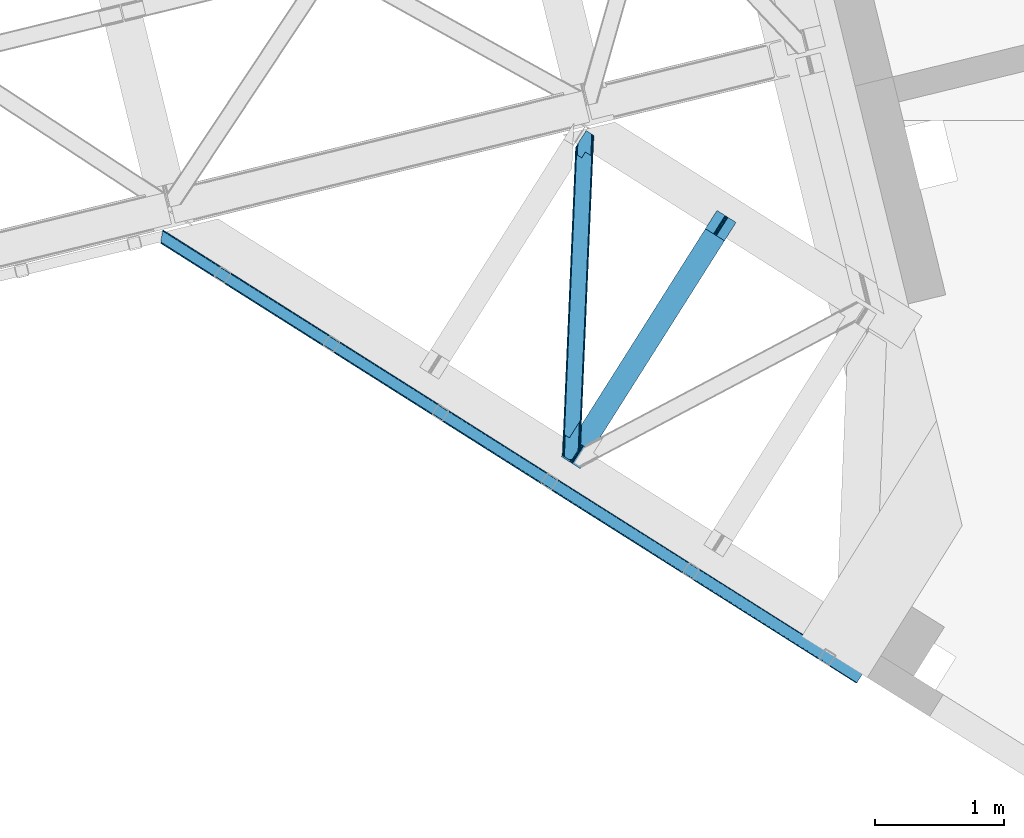
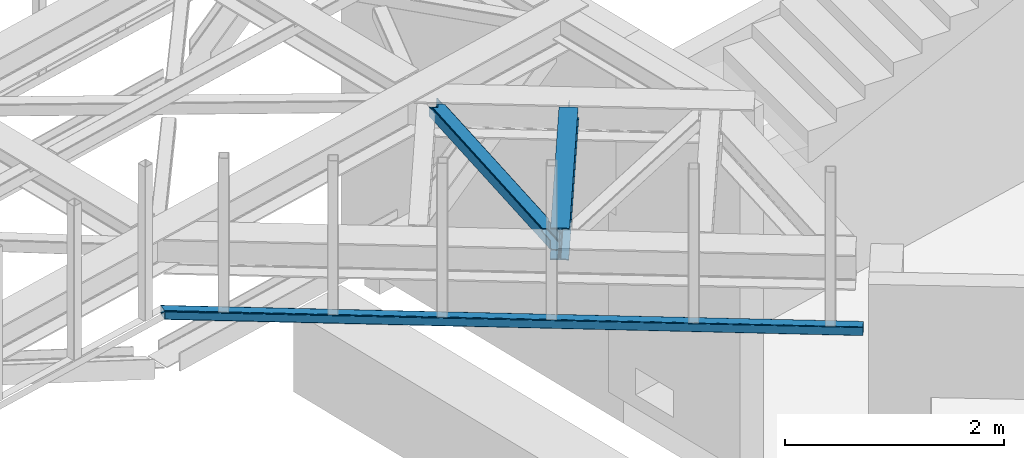
# One storey, part 49 of 66: 2 beams, 1 member.
"""IFC4 building model written with IfcOpenShell, lengths in millimetres."""

from ifc_helpers import new_model, entity, si_unit, converted_unit, derived_unit, direction, frame, origin, place, context, subcontext, project, spatial, triangles, polygons, material, type_object, element, save


model = new_model("IFC4")

# Units and contexts
model_context = context("Model", 3, precision=0.01, world=origin(), true_north=direction((6.12303176911189e-17, 1.0)))
plan_context = context("Plan", 3, precision=0.01, world=origin(), true_north=direction((6.12303176911189e-17, 1.0)))
body_context = subcontext(model_context, "Body", "Model", "MODEL_VIEW")
ifc_project = project(units=[si_unit("LENGTHUNIT", "METRE", prefix="MILLI"), si_unit("AREAUNIT", "SQUARE_METRE"), si_unit("VOLUMEUNIT", "CUBIC_METRE"), converted_unit("PLANEANGLEUNIT", "DEGREE", entity("IfcRatioMeasure", 0.0174532925199433), si_unit("PLANEANGLEUNIT", "RADIAN"), dimensions=[0, 0, 0, 0, 0, 0, 0]), si_unit("MASSUNIT", "GRAM", prefix="KILO"), derived_unit("MASSDENSITYUNIT", [(si_unit("MASSUNIT", "GRAM", prefix="KILO"), 1), (si_unit("LENGTHUNIT", "METRE"), -3)]), derived_unit("MOMENTOFINERTIAUNIT", [(si_unit("LENGTHUNIT", "METRE"), 4)]), si_unit("TIMEUNIT", "SECOND"), si_unit("FREQUENCYUNIT", "HERTZ"), si_unit("THERMODYNAMICTEMPERATUREUNIT", "DEGREE_CELSIUS"), derived_unit("THERMALTRANSMITTANCEUNIT", [(si_unit("MASSUNIT", "GRAM", prefix="KILO"), 1), (si_unit("THERMODYNAMICTEMPERATUREUNIT", "KELVIN"), -1), (si_unit("TIMEUNIT", "SECOND"), -3)]), derived_unit("VOLUMETRICFLOWRATEUNIT", [(si_unit("LENGTHUNIT", "METRE"), 3), (si_unit("TIMEUNIT", "SECOND"), -1)]), derived_unit("MASSFLOWRATEUNIT", [(si_unit("MASSUNIT", "GRAM", prefix="KILO"), 1), (si_unit("TIMEUNIT", "SECOND"), -1)]), derived_unit("ROTATIONALFREQUENCYUNIT", [(si_unit("TIMEUNIT", "SECOND"), -1)]), si_unit("ELECTRICCURRENTUNIT", "AMPERE"), si_unit("ELECTRICVOLTAGEUNIT", "VOLT"), si_unit("POWERUNIT", "WATT"), si_unit("FORCEUNIT", "NEWTON", prefix="KILO"), si_unit("ILLUMINANCEUNIT", "LUX"), si_unit("LUMINOUSFLUXUNIT", "LUMEN"), si_unit("LUMINOUSINTENSITYUNIT", "CANDELA"), derived_unit("USERDEFINED", [(si_unit("MASSUNIT", "GRAM", prefix="KILO"), -1), (si_unit("LENGTHUNIT", "METRE"), -2), (si_unit("TIMEUNIT", "SECOND"), 3), (si_unit("LUMINOUSFLUXUNIT", "LUMEN"), 1)]), derived_unit("LINEARVELOCITYUNIT", [(si_unit("LENGTHUNIT", "METRE"), 1), (si_unit("TIMEUNIT", "SECOND"), -1)]), si_unit("PRESSUREUNIT", "PASCAL"), derived_unit("USERDEFINED", [(si_unit("LENGTHUNIT", "METRE"), -2), (si_unit("MASSUNIT", "GRAM", prefix="KILO"), 1), (si_unit("TIMEUNIT", "SECOND"), -2)]), derived_unit("LINEARFORCEUNIT", [(si_unit("MASSUNIT", "GRAM", prefix="KILO"), 1), (si_unit("LENGTHUNIT", "METRE"), 1), (si_unit("TIMEUNIT", "SECOND"), -2), (si_unit("LENGTHUNIT", "METRE"), -1)]), derived_unit("PLANARFORCEUNIT", [(si_unit("MASSUNIT", "GRAM", prefix="KILO"), 1), (si_unit("LENGTHUNIT", "METRE"), 1), (si_unit("TIMEUNIT", "SECOND"), -2), (si_unit("LENGTHUNIT", "METRE"), -2)])], contexts=[model_context, plan_context])

# Site, building, storey
site_placement = place(None, origin())
site = spatial("IfcSite", under=ifc_project, at=site_placement, CompositionType="ELEMENT")
building_placement = place(site_placement, origin())
building = spatial("IfcBuilding", under=site, at=building_placement, CompositionType="ELEMENT")
storey_placement = place(building_placement, frame((0.0, 0.0, 19800.0)))
storey = spatial("IfcBuildingStorey", under=building, at=storey_placement, Name="06", CompositionType="ELEMENT", Elevation=19800.0)

# Beam
ifc_material = material(Name="Metal painted (White)")
beam_type_1 = type_object("IfcBeamType", PredefinedType="BEAM")
beam_1_placement = place(storey_placement, frame((-2373.15, 14260.29, 3864.0)))
element("IfcBeam", 1, at=beam_1_placement, inside=storey, type_object=beam_type_1, material=ifc_material, ObjectType="Steel Beam", PredefinedType="BEAM", context=body_context, shape_type="Tessellation", body=[
    polygons([(147.919660694801, 2.16573425859679e-12, 11.0000000000018), (147.919660694804, 4.33146851719357e-12, 0.0), (1355.44607863557, 1910.06544717356, 0.0), (1355.44607863557, 1910.06544717355, 11.0000000000018), (90.4423068248274, 36.3366728266057, 11.0000000000018), (1297.96872476558, 1946.40212000016, 11.0000000000018), (85.2668642219479, 39.6085416920184, 12.2179274798152), (1292.7932821627, 1949.67398886557, 12.2179274798152), (80.8793358398553, 42.3822981822298, 15.6862915010257), (1288.40575378062, 1952.44774535578, 15.6862915010213), (77.9476831016699, 44.2356630157985, 20.8770650821548), (1285.47410104242, 1954.30111018934, 20.8770650821548), (76.9182235613008, 44.8864781975669, 26.9999999999939), (1284.44464150205, 1954.95192537111, 26.9999999999939), (1278.52785507426, 1958.69246522089, 26.9999999999939), (1278.52785507432, 1958.69246522022, 203.000000000006), (1284.44464150196, 1954.95192537085, 203.000000000006), (1207.52641794078, 2003.57894341848, 0.0), (1207.52641794077, 2003.57894341847, 10.9999999999975), (1265.00377181074, 1967.24227059188, 11.0000000000018), (1270.17921441362, 1963.97040172646, 12.2179274798152), (1274.56674279571, 1961.19664523624, 15.6862915010127), (1277.49839553388, 1959.34328040268, 20.8770650821592), (76.9182235613823, 44.8864781975192, 203.000000000006), (71.0014371335516, 48.6270180473361, 203.000000000006), (71.0014371335056, 48.6270180473665, 26.9999999999939), (69.9719775931373, 49.2778332291413, 20.8770650821592), (67.0403248549565, 51.1311980626949, 15.6862915010127), (62.6527964728685, 53.9049545529128, 12.2179274798152), (57.4773538699869, 57.176823418332, 11.0000000000018), (8.12150346973795e-12, 93.5134962449225, 10.9999999999975), (5.41433564649196e-12, 93.5134962449269, 0.0), (162.887980343835, 180.873386503032, 203.069792575793), (1195.07248712349, 1813.58297531797, 203.006342981529), (1194.53809439775, 1812.73773730252, 216.999999999998), (163.217821525431, 181.395193639939, 216.999999999998), (163.217821525544, 181.395193639874, 204.00000000001), (156.766642341062, 184.290495421957, 203.006342980143), (157.301035097542, 185.135733489758, 216.999999999998), (1188.62130797009, 1816.4782771522, 216.999999999998), (1188.6213079702, 1816.47827715213, 204.000000000006), (1188.95114918025, 1817.00008434255, 203.069791966819), (157.301035097816, 185.135733489578, 204.00000000001), (164.247281065643, 180.744378458268, 223.122934917842), (167.178933803824, 178.891013624725, 228.313708498975), (171.566462185928, 176.117257134518, 231.782072520173), (176.741904788822, 172.845388269138, 232.999999999995), (234.219258658959, 136.508715442803, 232.999999999999), (234.219258658962, 136.508715442803, 243.999999999997), (86.2995979637529, 230.022211687052, 244.000000000001), (86.2995979637521, 230.022211687052, 232.999999999999), (143.776951833897, 193.685538860712, 232.999999999999), (148.952394436778, 190.413669995315, 231.782072520181), (153.339922818875, 187.639913505108, 228.313708498984), (156.271575557062, 185.786548671563, 223.122934917842), (1187.59184842946, 1817.12909233409, 223.122934917842), (1184.66019569129, 1818.98245716763, 228.313708498979), (1180.27266730917, 1821.75621365784, 231.782072520181), (1175.0972247063, 1825.02808252324, 232.999999999999), (1117.61987083616, 1861.36475534957, 232.999999999999), (1117.61987083616, 1861.36475534957, 244.000000000001), (1265.53953153138, 1767.85125910532, 243.999999999997), (1265.53953153137, 1767.85125910532, 232.999999999999), (1208.06217766123, 1804.18793193166, 232.999999999995), (1202.88673505832, 1807.45980079704, 231.782072520173), (1198.49920667623, 1810.23355728725, 228.313708498975), (1195.56755393804, 1812.08692212079, 223.122934917842), (1194.53809439802, 1812.73773730233, 204.000000000006)], [[[1, 2, 3, 4]], [[5, 1, 4, 6]], [[7, 5, 6, 8]], [[9, 7, 8, 10]], [[11, 9, 10, 12]], [[13, 11, 12, 14]], [[15, 16, 17, 14, 12, 10, 8, 6, 4, 3, 18, 19, 20, 21, 22, 23]], [[13, 24, 25, 26, 27, 28, 29, 30, 31, 32, 2, 1, 5, 7, 9, 11]], [[2, 32, 18, 3]], [[32, 31, 19, 18]], [[31, 30, 20, 19]], [[27, 26, 15, 23]], [[28, 27, 23, 22]], [[29, 28, 22, 21]], [[30, 29, 21, 20]], [[33, 24, 13, 14, 17, 34, 35, 36, 37]], [[25, 38, 39, 40, 41, 42, 16, 15, 26]], [[38, 25, 24, 33]], [[42, 34, 17, 16]], [[39, 43, 37, 36, 44, 45, 46, 47, 48, 49, 50, 51, 52, 53, 54, 55]], [[40, 56, 57, 58, 59, 60, 61, 62, 63, 64, 65, 66, 67, 35, 68, 41]], [[44, 36, 35, 67]], [[45, 44, 67, 66]], [[46, 45, 66, 65]], [[47, 46, 65, 64]], [[48, 47, 64, 63]], [[49, 48, 63, 62]], [[50, 49, 62, 61]], [[51, 50, 61, 60]], [[52, 51, 60, 59]], [[53, 52, 59, 58]], [[54, 53, 58, 57]], [[55, 54, 57, 56]], [[39, 55, 56, 40]]], closed=False),
])

# Member
member_type = type_object("IfcMemberType", PredefinedType="BRACE")
member_placement = place(storey_placement, frame((-2366.79, 14329.55, 3964.0)))
element("IfcMember", 2, at=member_placement, inside=storey, type_object=member_type, ObjectType="Steel Horizontal Brace", PredefinedType="BRACE", context=body_context, shape_type="Tessellation", body=[
    triangles([(100.655629348755, 2374.38995361328, 113.0000793457), (107.475271224976, 2370.07742614746, 113.0000793457), (102.696783828736, 2421.82891845703, 113.0000793457), (109.879194259644, 2433.19217834473, 113.0000793457), (110.120894622803, 2433.18287658691, 113.0000793457), (107.407542800903, 2370.08091430664, 113.0000793457), (110.142259597778, 2433.72354125977, 112.135015869138), (107.407397460938, 2370.08091430664, 115.49992675781), (13.930835723877, 195.896182250977, 115.49992675781), (110.180774688721, 2433.72237854004, 24.4985046386719), (13.8035179138183, 192.844042968751, 111.22111816406), (6.85336074829092, 30.4120971679695, 24.4985046386719), (13.6123958587646, 188.365246582032, 109.609588623047), (13.4169136047362, 183.884124755859, 108.000384521481), (6.81949653625497, 30.4144226074222, 108.000384521481), (0.0, 34.7257873535164, 108.000384521481), (6.82414741516141, 30.4144226074222, 108.000384521481), (13.4262153625491, 183.885287475587, 108.000384521481), (6.6020679473877, 188.196652221681, 108.000384521481), (6.98896293640155, 197.155407714845, 111.22111816406), (13.808604812622, 192.842880249023, 111.22111816406), (13.9405735015871, 195.89501953125, 115.49992675781), (14.3164226531985, 196.336853027344, 118.999713134763), (7.14723815917978, 200.865646362305, 118.999713134763), (7.06817321777362, 199.011108398438, 115.109252929688), (13.6174827575683, 188.364083862305, 109.609588623047), (6.79784088134784, 192.676611328125, 109.609588623047), (15.8281036376952, 195.378771972657, 121.887908935547), (108.771703720093, 2369.25654602051, 122.19719238281), (112.471768569947, 2366.92064208984, 127.873590087889), (107.475271224976, 2370.07742614746, 115.49992675781), (18.9633773803712, 193.396334838868, 127.873590087889), (118.001518249512, 2363.42318115235, 131.666381835938), (24.4974872589114, 189.900036621095, 131.666381835938), (124.526556015015, 2359.29668884277, 132.998858642575), (31.0226703643798, 185.773544311523, 132.998858642575), (129.009131240845, 2463.45079650879, 6.99957275390625), (121.8158203125, 2452.07358398438, 8.33204956054396), (23.8754322052005, 19.6336853027351, 6.99957275390625), (17.3502490997316, 23.7590148925792, 8.33204956054396), (115.717791366577, 2442.42882385254, 12.1248413085923), (11.8161392211914, 27.2564758300778, 12.1248413085923), (111.644784164429, 2435.9838684082, 17.8035644531228), (8.12043457031268, 29.5935424804684, 17.8035644531228), (110.214638900757, 2433.72121582031, 24.4985046386719), (6.82414741516141, 30.4144226074222, 24.4985046386719), (102.696783828736, 2421.82891845703, 17.4989318847656), (100.655629348755, 2374.38995361328, 122.499499511716), (7.14723815917978, 200.865646362305, 122.499499511716), (0.0, 34.7257873535164, 17.4989318847656), (117.706914138794, 2363.6092163086, 139.998431396481), (111.181876373291, 2367.73570861817, 138.668280029295), (17.6778453826905, 194.212564086914, 138.668280029295), (24.2030284881594, 190.086071777345, 139.998431396481), (105.647621154785, 2371.23200683594, 134.873162841795), (12.1437355041503, 197.708862304688, 134.873162841795), (101.952061843872, 2373.56907348633, 129.196765136716), (8.44817619323749, 200.045928955078, 129.196765136716), (151.68507270813, 2342.12680664063, 132.998858642575), (151.68507270813, 2342.12680664063, 139.998431396481), (56.1432300567626, 169.89428100586, 132.998858642575), (56.1432300567626, 169.89428100586, 139.998431396481), (104.126929092407, 2424.09273376465, 10.8016662597656), (1.30093803405771, 33.9060699462898, 10.8016662597656), (108.200081634522, 2430.53652648926, 5.12526855468604), (4.99649734497098, 31.5690032958992, 5.12526855468604), (114.298110580444, 2440.18244934082, 1.33247680663771), (10.5307525634767, 28.0715423583988, 1.33247680663771), (121.491276168823, 2451.55966186523, 0.0), (17.0557903289796, 23.9462127685547, 0.0), (186.00768699646, 2553.61506042481, 6.99957275390625), (186.00768699646, 2553.61506042481, 0.0), (110.214638900757, 2433.72121582031, 112.135015869138), (53.3593883514404, 0.995288085938228, 6.99957275390625), (53.3593883514404, 0.995288085938228, 0.0), (76.5082660675048, 0.0, 0.0), (76.5082660675048, 0.0, 6.99957275390625), (124.379326629639, 75.7232849121101, 0.0), (229.786700820923, 2525.94000549316, 0.0), (116.861471557617, 63.8309875488285, 6.99957275390625), (222.967058944702, 2530.25253295898, 6.99957275390625), (236.311738586426, 2521.8135131836, 1.33247680663771), (131.572637557983, 87.1004974365242, 1.33247680663771), (241.845993804932, 2518.31721496582, 5.12526855468604), (137.670666503906, 96.7452575683601, 5.12526855468604), (245.541553115845, 2515.98014831543, 10.8016662597656), (141.743673706055, 103.190213012696, 10.8016662597656), (246.837985610962, 2515.15926818848, 17.4989318847656), (143.173964309693, 105.452865600586, 17.4989318847656), (240.018343734741, 2519.4717956543, 24.4985046386719), (238.721911239624, 2520.29267578125, 17.8035644531228), (135.656109237671, 93.5605682373043, 24.4985046386719), (134.225963973999, 91.2979156494148, 17.8035644531228), (235.026351928711, 2522.62974243164, 12.1248413085923), (130.152811431885, 84.8529602050785, 12.1248413085923), (229.492096710205, 2526.12604064941, 8.33204956054396), (124.054782485962, 75.2082000732426, 8.33204956054396), (143.173964309693, 105.452865600586, 108.000384521481), (135.656109237671, 93.5605682373043, 108.000384521481), (246.837985610962, 2515.15926818848, 108.000384521481), (240.018343734741, 2519.4717956543, 108.000384521481), (144.900748443604, 308.420709228516, 108.000384521481), (152.418603515625, 320.313006591798, 108.000384521481), (233.416130447388, 2366.00093078613, 108.000384521481), (240.235772323609, 2361.68840332031, 108.000384521481), (233.02938079834, 2357.04217529297, 111.22111816406), (233.225008392334, 2361.52213439942, 109.609588623047), (232.901917648316, 2353.99003601074, 115.49992675781), (144.985917663574, 310.428726196289, 109.000323486325), (144.943333053589, 309.42413635254, 108.500354003903), (144.985917663574, 310.428726196289, 115.49992675781), (143.555627059937, 308.164910888672, 122.19719238281), (152.50362739563, 322.321023559571, 122.499499511716), (151.073482131958, 320.057208251954, 129.196765136716), (147.00047492981, 313.613415527345, 134.873162841795), (139.482619857788, 301.721118164063, 127.873590087889), (152.50362739563, 322.321023559571, 109.000323486325), (140.902445983887, 303.967492675782, 138.668280029295), (133.384590911865, 292.076358032227, 131.666381835938), (133.709135055542, 292.590280151368, 139.998431396481), (126.19127998352, 280.697982788086, 132.998858642575), (239.853528213501, 2352.73081054688, 111.22111816406), (239.774317932129, 2350.87510986328, 115.109252929688), (240.044650268555, 2357.20960693359, 109.609588623047), (239.690747451783, 2349.01940917969, 118.999713134763), (239.690747451783, 2349.01940917969, 122.499499511716), (152.461188125611, 321.316433715821, 108.500354003903), (222.639462661743, 2359.80014648438, 139.998431396481), (179.929569625855, 2386.80082397461, 139.998431396481), (215.819820785523, 2364.1126739502, 132.998858642575), (179.929569625855, 2386.80082397461, 132.998858642575), (234.698755645752, 2352.17735595703, 134.873162841795), (227.879113769531, 2356.48988342285, 127.873590087889), (229.164500427246, 2355.67365417481, 138.668280029295), (231.014387512207, 2354.50628356934, 121.887908935547), (238.394314956665, 2349.84028930664, 129.196765136716), (232.526068496704, 2353.54936523438, 118.999713134763), (222.344858551025, 2359.98618164063, 131.666381835938)], [[1, 2, 3], [4, 3, 2], [5, 6, 7], [6, 8, 9], [6, 10, 7], [6, 11, 10], [9, 11, 6], [12, 10, 11], [13, 12, 11], [12, 13, 14], [15, 12, 14], [16, 17, 18], [18, 19, 16], [20, 21, 22], [23, 24, 25], [25, 22, 23], [22, 25, 20], [26, 21, 27], [20, 27, 21], [18, 26, 19], [27, 19, 26], [28, 29, 30], [29, 28, 23], [23, 31, 29], [23, 22, 31], [30, 32, 28], [30, 33, 32], [34, 32, 33], [33, 35, 34], [36, 34, 35], [37, 38, 39], [40, 39, 38], [38, 41, 40], [42, 40, 41], [41, 43, 42], [44, 42, 43], [43, 45, 44], [46, 44, 45], [1, 25, 24], [47, 20, 1], [1, 3, 47], [24, 48, 1], [49, 48, 24], [20, 47, 50], [50, 19, 27], [50, 16, 19], [27, 20, 50], [20, 25, 1], [51, 52, 53], [53, 54, 51], [52, 55, 56], [56, 53, 52], [55, 57, 58], [58, 56, 55], [57, 48, 49], [49, 58, 57], [30, 52, 55], [59, 60, 35], [60, 51, 35], [52, 33, 51], [30, 33, 52], [33, 35, 51], [48, 31, 29], [57, 30, 55], [30, 57, 29], [57, 48, 29], [1, 31, 48], [1, 2, 31], [32, 53, 56], [61, 62, 36], [62, 54, 36], [53, 34, 54], [32, 34, 53], [34, 36, 54], [58, 28, 32], [56, 58, 32], [28, 58, 49], [49, 23, 28], [49, 24, 23], [47, 63, 64], [64, 50, 47], [63, 65, 66], [66, 64, 63], [65, 67, 68], [68, 66, 65], [67, 69, 70], [70, 68, 67], [41, 65, 67], [41, 67, 38], [37, 38, 69], [43, 65, 41], [71, 37, 72], [69, 72, 37], [38, 67, 69], [63, 65, 43], [3, 47, 45], [45, 73, 3], [4, 3, 73], [63, 43, 47], [43, 45, 47], [68, 42, 66], [40, 70, 39], [74, 39, 75], [40, 42, 68], [39, 70, 75], [40, 68, 70], [64, 66, 42], [16, 50, 46], [44, 46, 50], [17, 16, 46], [42, 44, 64], [44, 50, 64], [76, 77, 75], [74, 75, 77], [70, 78, 75], [78, 70, 69], [76, 75, 78], [69, 79, 78], [79, 69, 72], [74, 77, 80], [39, 80, 37], [80, 39, 74], [81, 37, 80], [81, 71, 37], [79, 82, 83], [83, 78, 79], [82, 84, 85], [85, 83, 82], [84, 86, 87], [87, 85, 84], [86, 88, 89], [89, 87, 86], [90, 91, 92], [93, 92, 91], [91, 94, 93], [95, 93, 94], [94, 96, 95], [97, 95, 96], [96, 81, 97], [80, 97, 81], [85, 93, 95], [92, 89, 98], [98, 99, 92], [92, 93, 89], [93, 87, 89], [93, 85, 87], [83, 85, 95], [80, 78, 97], [95, 97, 83], [80, 77, 76], [97, 78, 83], [80, 76, 78], [91, 90, 88], [88, 86, 91], [94, 86, 84], [86, 94, 91], [90, 100, 88], [90, 101, 100], [94, 84, 82], [96, 82, 79], [72, 81, 79], [71, 81, 72], [81, 96, 79], [96, 94, 82], [99, 98, 102], [103, 102, 98], [104, 105, 100], [100, 101, 104], [106, 90, 102], [104, 90, 107], [104, 101, 90], [108, 106, 109], [106, 107, 90], [110, 109, 106], [92, 102, 90], [92, 99, 102], [102, 110, 106], [109, 111, 108], [112, 111, 113], [113, 114, 112], [115, 112, 114], [112, 115, 116], [111, 117, 113], [111, 109, 117], [116, 115, 118], [119, 118, 120], [62, 121, 120], [61, 121, 62], [121, 119, 120], [119, 116, 118], [88, 122, 117], [123, 117, 122], [124, 122, 88], [88, 105, 124], [105, 88, 100], [103, 89, 88], [113, 125, 126], [88, 117, 127], [123, 125, 117], [117, 125, 113], [88, 127, 103], [89, 103, 98], [120, 51, 60], [51, 120, 54], [62, 54, 120], [60, 128, 120], [128, 60, 129], [121, 35, 59], [35, 121, 36], [61, 36, 121], [59, 130, 121], [130, 59, 131], [132, 133, 134], [135, 136, 126], [126, 125, 137], [137, 135, 126], [133, 136, 135], [132, 136, 133], [138, 128, 134], [134, 133, 138], [138, 130, 128], [130, 129, 128], [131, 129, 130], [133, 135, 112], [135, 137, 111], [111, 112, 135], [137, 108, 111], [112, 116, 133], [138, 133, 116], [116, 119, 138], [130, 138, 119], [119, 121, 130], [137, 125, 123], [122, 106, 108], [124, 105, 107], [104, 107, 105], [122, 124, 106], [107, 106, 124], [108, 123, 122], [123, 108, 137], [126, 136, 113], [114, 113, 136], [136, 132, 114], [115, 114, 132], [132, 134, 115], [118, 115, 134], [134, 128, 118], [120, 118, 128], [129, 131, 60], [59, 60, 131]]),
])

# Beam
beam_type_2 = type_object("IfcBeamType", PredefinedType="BEAM")
beam_2_placement = place(storey_placement, frame((-5482.2, 12594.3, 3278.0)))
element("IfcBeam", 3, at=beam_2_placement, inside=storey, type_object=beam_type_2, ObjectType="Steel Beam", PredefinedType="BEAM", context=body_context, shape_type="Tessellation", body=[
    triangles([(15.8013610839844, 3509.74390869141, 99.9985473632805), (1.75279998779297, 3423.97705078125, 99.9985473632805), (5447.18182697296, 76.072100830077, 99.9985473632805), (5404.4346269846, 8.45180969238208, 99.9985473632805), (1.13539581298846, 3420.18774719238, 98.5358459472664), (5402.38918497562, 5.21712341308557, 99.2381286621094), (0.512759399413881, 3416.39728088379, 97.0708190917976), (5400.6545797348, 2.47543029785083, 97.0708190917976), (0.254635620117369, 3414.8264465332, 93.5361511230476), (5399.49745559692, 0.642984008789426, 93.8268310546882), (0.0, 3413.25677490234, 89.999157714843), (5399.08948631287, 0.0, 89.999157714843), (5399.08948631287, 0.0, 9.9993896484375), (0.0, 3413.25677490234, 9.9993896484375), (5399.49745559692, 0.642984008789426, 6.17171630859229), (5400.6545797348, 2.47543029785083, 2.92772827148292), (0.254635620117369, 3414.8264465332, 6.4647216796875), (5402.38918497562, 5.21712341308557, 0.760418701171147), (0.512759399413881, 3416.39728088379, 2.92772827148292), (5404.4346269846, 8.45180969238208, 0.0), (1.13539581298846, 3420.18774719238, 1.46502685546875), (1.75279998779297, 3423.97705078125, 0.0), (15.8013610839844, 3509.74390869141, 0.0), (5447.18182697296, 76.072100830077, 0.0), (5449.22727352381, 79.3067871093754, 0.760418701171147), (5450.96187422276, 82.0496429443356, 2.92772827148292), (16.4234161376953, 3513.53553771973, 1.46502685546875), (5452.11893250346, 83.8820892333988, 6.17171630859229), (17.0414016723635, 3517.32484130859, 2.92772827148292), (5452.52690405846, 84.5250732421864, 9.9993896484375), (17.3001068115236, 3518.89451293945, 6.4647216796875), (17.5588119506838, 3520.46534729004, 9.9993896484375), (5452.52690405846, 84.5250732421864, 89.999157714843), (17.5588119506838, 3520.46534729004, 89.999157714843), (17.3001068115236, 3518.89451293945, 93.5361511230476), (5452.11893250346, 83.8820892333988, 93.8268310546882), (17.0414016723635, 3517.32484130859, 97.0708190917976), (5450.96187422276, 82.0496429443356, 97.0708190917976), (16.4234161376953, 3513.53553771973, 98.5358459472664), (5449.22727352381, 79.3067871093754, 99.2381286621094), (5448.29159526229, 77.8231567382809, 92.0711242675789), (5449.448653543, 79.6556030273441, 88.8271362304695), (5449.85662509799, 80.299749755859, 84.9994628906243), (5444.5115480125, 71.8467773437496, 94.9988525390618), (5446.5569241643, 75.0814636230461, 94.2384338378906), (5448.29159526229, 77.8231567382809, 7.92742309570167), (5449.85662509799, 80.299749755859, 14.9990844726563), (5449.448653543, 79.6556030273441, 11.1737365722656), (5444.5115480125, 71.8467773437496, 4.99969482421875), (5446.5569241643, 75.0814636230461, 5.7601135253899), (5403.32938013077, 6.70191650390552, 92.0711242675789), (5407.104908216, 12.6782958984368, 94.9988525390618), (5405.05946166515, 9.44360961914026, 94.2384338378906), (5401.76427762508, 4.22648620605469, 84.9994628906243), (5402.16773228645, 4.86947021484411, 88.8271362304695), (5403.32938013077, 6.70191650390552, 7.92742309570167), (5407.104908216, 12.6782958984368, 4.99969482421875), (5405.05946166515, 9.44360961914026, 5.7601135253899), (5401.76427762508, 4.22648620605469, 14.9990844726563), (5402.16773228645, 4.86947021484411, 11.1737365722656), (16.4234161376953, 3513.53553771973, 11.4644165039063), (16.677470397949, 3515.10404663086, 14.9990844726563), (16.1647109985352, 3511.96470336914, 7.92742309570167), (14.9252517700197, 3504.38377075195, 4.99969482421875), (15.5426559448242, 3508.17423706055, 6.4647216796875), (16.1647109985352, 3511.96470336914, 92.0711242675789), (16.677470397949, 3515.10404663086, 84.9994628906243), (16.4234161376953, 3513.53553771973, 88.5341308593743), (15.5426559448242, 3508.17423706055, 93.5361511230476), (14.9252517700197, 3504.38377075195, 94.9988525390618), (1.38945007324219, 3421.75741882324, 7.92742309570167), (1.13539581298846, 3420.18774719238, 11.4644165039063), (2.63356018066406, 3429.33835144043, 4.99969482421875), (2.01150512695313, 3425.54788513184, 6.4647216796875), (0.876690673828307, 3418.6169128418, 14.9990844726563), (2.01150512695313, 3425.54788513184, 93.5361511230476), (1.38945007324219, 3421.75741882324, 92.0711242675789), (1.13539581298846, 3420.18774719238, 88.5341308593743), (2.63356018066406, 3429.33835144043, 94.9988525390618), (0.876690673828307, 3418.6169128418, 84.9994628906243)], [[1, 2, 3], [4, 3, 2], [4, 2, 5], [6, 5, 7], [8, 7, 9], [10, 9, 11], [11, 12, 10], [9, 10, 8], [7, 8, 6], [5, 6, 4], [13, 12, 11], [11, 14, 13], [15, 13, 14], [16, 15, 17], [18, 16, 19], [20, 18, 21], [21, 22, 20], [19, 21, 18], [17, 19, 16], [14, 17, 15], [22, 23, 24], [24, 20, 22], [25, 24, 23], [26, 25, 27], [28, 26, 29], [30, 28, 31], [31, 32, 30], [29, 31, 28], [27, 29, 26], [23, 27, 25], [33, 30, 34], [32, 34, 30], [33, 34, 35], [36, 35, 37], [38, 37, 39], [40, 39, 1], [1, 3, 40], [39, 40, 38], [37, 38, 36], [35, 36, 33], [36, 41, 42], [43, 30, 33], [36, 42, 33], [36, 38, 41], [42, 43, 33], [41, 38, 40], [44, 3, 4], [3, 45, 40], [45, 3, 44], [45, 41, 40], [28, 46, 26], [47, 30, 43], [30, 48, 28], [48, 30, 47], [28, 48, 46], [24, 49, 20], [25, 26, 46], [46, 50, 25], [50, 49, 24], [24, 25, 50], [51, 6, 8], [4, 52, 44], [4, 53, 52], [53, 4, 6], [51, 53, 6], [54, 12, 13], [10, 55, 51], [8, 10, 51], [55, 10, 12], [54, 55, 12], [18, 56, 16], [20, 49, 57], [57, 58, 20], [58, 56, 18], [18, 20, 58], [15, 16, 56], [13, 59, 54], [60, 13, 15], [13, 60, 59], [60, 15, 56], [61, 62, 32], [63, 31, 29], [63, 29, 27], [32, 62, 34], [32, 31, 61], [63, 61, 31], [64, 23, 22], [27, 23, 65], [64, 65, 23], [27, 65, 63], [66, 39, 37], [67, 34, 62], [68, 35, 34], [68, 34, 67], [37, 35, 66], [39, 69, 1], [35, 68, 66], [39, 66, 69], [1, 70, 2], [70, 1, 69], [71, 17, 72], [22, 73, 64], [22, 21, 74], [22, 74, 73], [74, 21, 71], [72, 14, 75], [17, 71, 19], [19, 71, 21], [75, 14, 11], [17, 14, 72], [5, 2, 76], [77, 5, 76], [78, 9, 77], [79, 2, 70], [2, 79, 76], [77, 7, 5], [11, 80, 75], [9, 78, 11], [80, 11, 78], [9, 7, 77], [79, 70, 44], [44, 52, 79], [55, 54, 80], [51, 55, 78], [53, 51, 77], [52, 53, 76], [76, 79, 52], [77, 76, 53], [78, 77, 51], [80, 78, 55], [54, 59, 80], [75, 80, 59], [57, 73, 74], [58, 74, 71], [56, 71, 72], [60, 72, 75], [75, 59, 60], [72, 60, 56], [71, 56, 58], [74, 58, 57], [64, 73, 49], [57, 49, 73], [47, 62, 61], [48, 61, 63], [46, 63, 65], [50, 65, 64], [64, 49, 50], [65, 50, 46], [63, 46, 48], [61, 48, 47], [47, 43, 67], [67, 62, 47], [45, 44, 70], [41, 45, 69], [42, 41, 66], [43, 42, 68], [68, 67, 43], [66, 68, 42], [69, 66, 41], [70, 69, 45]]),
])

save(model, "model.ifc")
